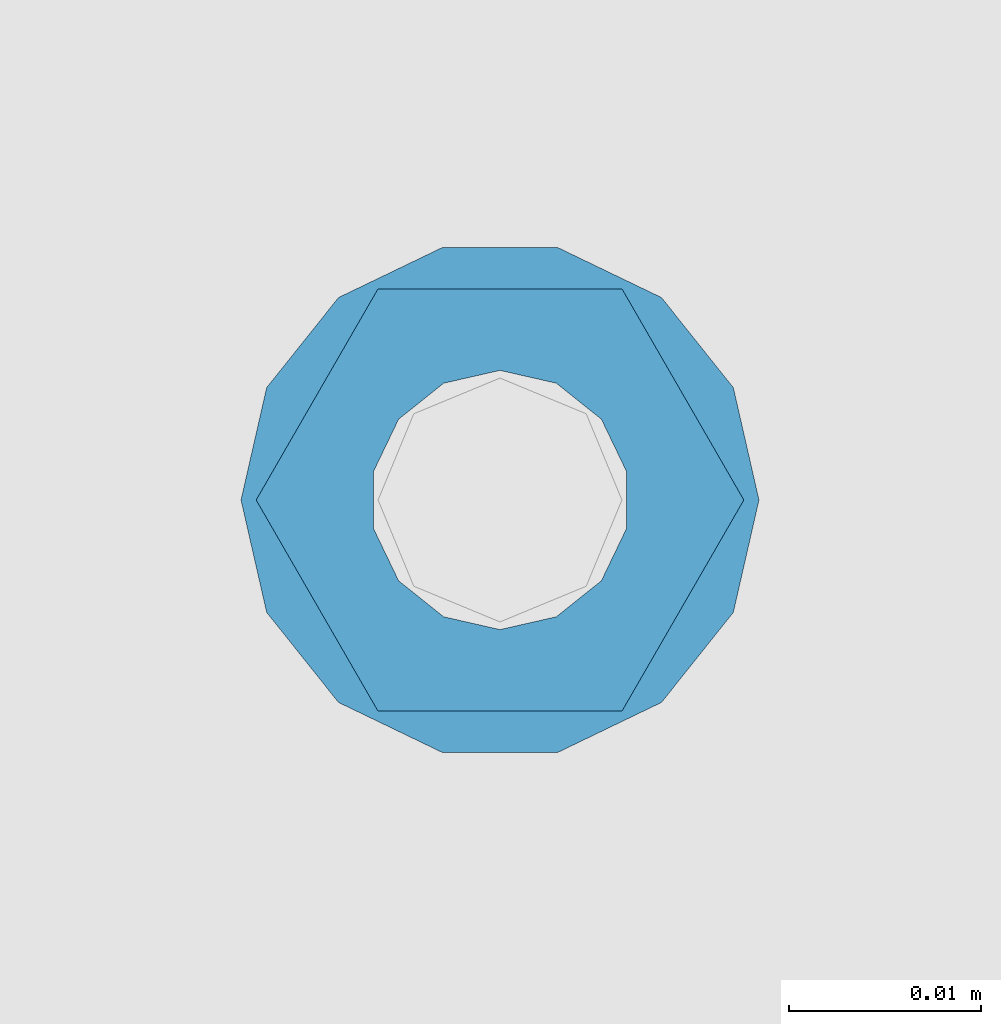
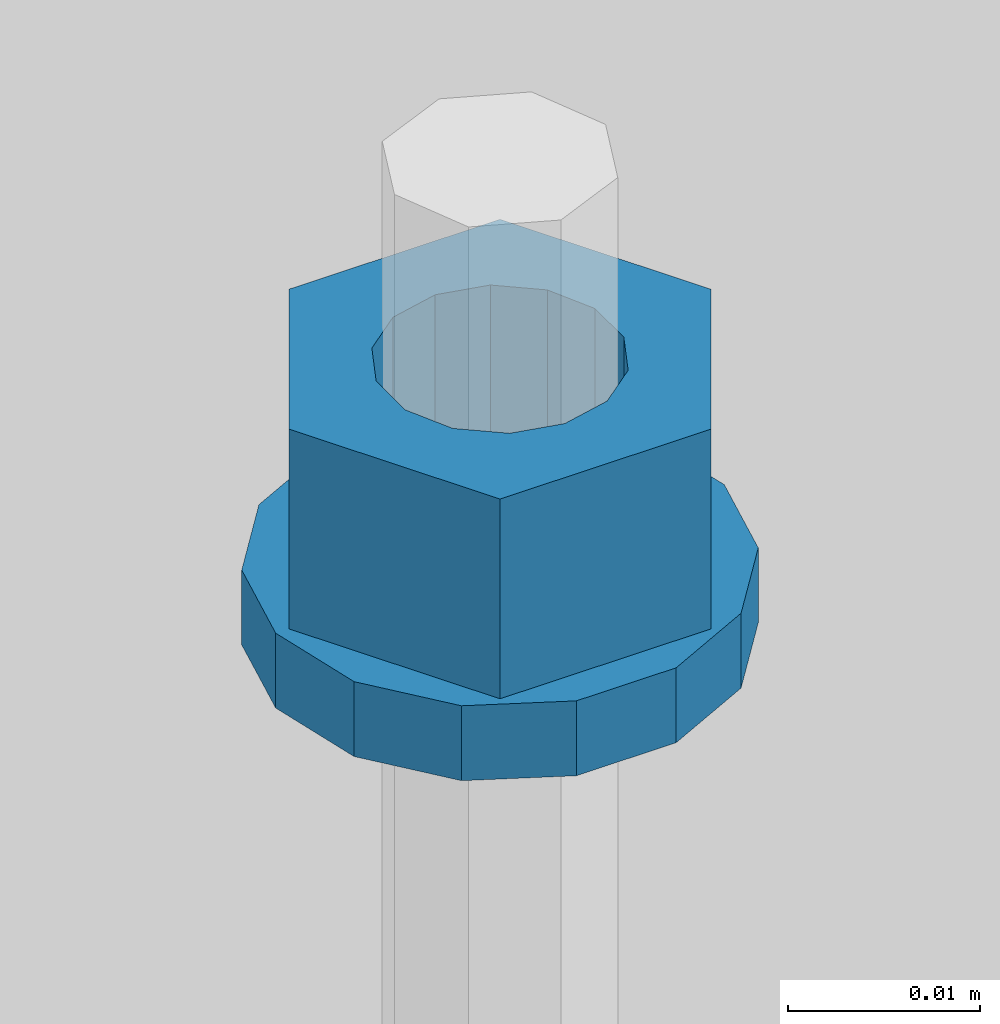
# One storey, part 651 of 1179: 2 columns, 1 element without a shape of its own.
"""IFC2X3 building model written with IfcOpenShell, lengths in millimetres."""

from ifc_helpers import new_model, si_unit, frame, origin_with_axes, place, context, subcontext, project, spatial, faceted_brep, material, type_object, element, aggregate, save


model = new_model("IFC2X3")

# Units and contexts
model_context = context("Model", 3, precision=1e-05, world=origin_with_axes())
body_context = subcontext(model_context, "Body", "Model", "MODEL_VIEW")
ifc_project = project(units=[si_unit("LENGTHUNIT", "METRE", prefix="MILLI"), si_unit("AREAUNIT", "SQUARE_METRE"), si_unit("VOLUMEUNIT", "CUBIC_METRE"), si_unit("MASSUNIT", "GRAM", prefix="KILO"), si_unit("TIMEUNIT", "SECOND"), si_unit("PLANEANGLEUNIT", "RADIAN"), si_unit("SOLIDANGLEUNIT", "STERADIAN"), si_unit("THERMODYNAMICTEMPERATUREUNIT", "DEGREE_CELSIUS"), si_unit("LUMINOUSINTENSITYUNIT", "LUMEN")], contexts=[model_context])

# Site, building, storey
site_placement = place(None, origin_with_axes())
site = spatial("IfcSite", under=ifc_project, at=site_placement, CompositionType="ELEMENT")
building_placement = place(site_placement, origin_with_axes())
building = spatial("IfcBuilding", under=site, at=building_placement, Name="Undefined", CompositionType="ELEMENT")
storey_placement = place(building_placement, origin_with_axes())
storey = spatial("IfcBuildingStorey", under=building, at=storey_placement, Name="Undefined", CompositionType="ELEMENT", Elevation=0.0)

# Assembly, columns
assembly_placement = place(storey_placement, origin_with_axes())
assembly = element("IfcElementAssembly", 1, at=assembly_placement, inside=storey, Name="BEAM", AssemblyPlace="NOTDEFINED", PredefinedType="RIGID_FRAME")
ifc_material = material(Name="STEEL/A307")
column_type_1 = type_object("IfcColumnType", Name="1/2_WASHER", PredefinedType="NOTDEFINED")
column_1_placement = place(assembly_placement, frame((1269.99998779297, 41529.0, 4235.45), z_axis=(0.0, 1.0, 0.0), x_axis=(0.0, 0.0, 1.0)))
column_1 = element("IfcColumn", 2, at=column_1_placement, type_object=column_type_1, material=ifc_material, Name="WASHER", ObjectType="1/2_WASHER", context=body_context, shape_type="Brep", body=[
    faceted_brep([(0.0, -13.4899997711182, 0.0), (0.0, -12.1540698217868, -5.85309154138758), (4.76249999999891, -12.1540698217868, -5.85309154138758), (4.76249999999891, -13.4899997711182, 0.0), (0.0, -8.41087728436833, -10.5469065195466), (4.76249999999891, -8.41087728436833, -10.5469065195466), (0.0, -3.00180734814057, -13.1517773121896), (4.76249999999891, -3.00180734814057, -13.1517773121896), (0.0, 3.00180734814057, -13.1517773121896), (4.76249999999891, 3.00180734814057, -13.1517773121896), (0.0, 8.41087728436833, -10.5469065195466), (4.76249999999891, 8.41087728436833, -10.5469065195466), (0.0, 12.1540698217868, -5.85309154138758), (4.76249999999891, 12.1540698217868, -5.85309154138758), (0.0, 13.4899997711182, 0.0), (4.76249999999891, 13.4899997711182, 0.0), (0.0, 12.1540698217868, 5.85309154138758), (4.76249999999891, 12.1540698217868, 5.85309154138758), (0.0, 8.41087728436833, 10.5469065195466), (4.76249999999891, 8.41087728436833, 10.5469065195466), (0.0, 3.00180734814057, 13.1517773121896), (4.76249999999891, 3.00180734814057, 13.1517773121896), (0.0, -3.00180734814057, 13.1517773121896), (4.76249999999891, -3.00180734814057, 13.1517773121896), (0.0, -8.41087728436833, 10.5469065195466), (4.76249999999891, -8.41087728436833, 10.5469065195466), (0.0, -12.1540698217868, 5.85309154138758), (4.76249999999891, -12.1540698217868, 5.85309154138758), (0.0, 0.0, 6.75), (0.0, 2.9287152390425, 6.08153985834178), (4.76249999999891, 2.9287152390425, 6.08153985834178), (4.76249999999891, 0.0, 6.75), (0.0, 5.27736250665839, 4.2085561625463), (4.76249999999891, 5.27736250665839, 4.2085561625463), (0.0, 6.58076340722619, 1.50201630420543), (4.76249999999891, 6.58076340722619, 1.50201630420543), (0.0, 6.58076340722619, -1.50201630420543), (4.76249999999891, 6.58076340722619, -1.50201630420543), (0.0, 5.27736250665839, -4.2085561625463), (4.76249999999891, 5.27736250665839, -4.2085561625463), (0.0, 2.9287152390425, -6.08153985834088), (4.76249999999891, 2.9287152390425, -6.08153985834088), (0.0, 0.0, -6.75), (4.76249999999891, 0.0, -6.75), (0.0, -2.9287152390425, -6.08153985834178), (4.76249999999891, -2.9287152390425, -6.08153985834178), (0.0, -5.27736250665839, -4.2085561625463), (4.76249999999891, -5.27736250665839, -4.2085561625463), (0.0, -6.58076340722619, -1.50201630420543), (4.76249999999891, -6.58076340722619, -1.50201630420543), (0.0, -6.58076340722619, 1.50201630420543), (4.76249999999891, -6.58076340722619, 1.50201630420543), (0.0, -5.27736250665839, 4.2085561625463), (4.76249999999891, -5.27736250665839, 4.2085561625463), (0.0, -2.9287152390425, 6.08153985834088), (4.76249999999891, -2.9287152390425, 6.08153985834088)], [[[0, 1, 2, 3]], [[1, 4, 5, 2]], [[4, 6, 7, 5]], [[6, 8, 9, 7]], [[8, 10, 11, 9]], [[10, 12, 13, 11]], [[12, 14, 15, 13]], [[14, 16, 17, 15]], [[16, 18, 19, 17]], [[18, 20, 21, 19]], [[20, 22, 23, 21]], [[22, 24, 25, 23]], [[24, 26, 27, 25]], [[26, 0, 3, 27]], [[28, 29, 30, 31]], [[29, 32, 33, 30]], [[32, 34, 35, 33]], [[34, 36, 37, 35]], [[36, 38, 39, 37]], [[38, 40, 41, 39]], [[40, 42, 43, 41]], [[42, 44, 45, 43]], [[44, 46, 47, 45]], [[46, 48, 49, 47]], [[48, 50, 51, 49]], [[50, 52, 53, 51]], [[52, 54, 55, 53]], [[54, 28, 31, 55]], [[5, 7, 9, 11, 13, 15, 17, 19, 21, 23, 25, 27, 3, 2], [33, 35, 37, 39, 41, 43, 45, 47, 49, 51, 53, 55, 31, 30]], [[26, 24, 22, 20, 18, 16, 14, 12, 10, 8, 6, 4, 1, 0], [54, 52, 50, 48, 46, 44, 42, 40, 38, 36, 34, 32, 29, 28]]]),
])
column_type_2 = type_object("IfcColumnType", Name="1/2_HEAVY_HEX_NUT", PredefinedType="NOTDEFINED")
column_2_placement = place(assembly_placement, frame((1269.99998779297, 41529.0, 4240.2125), z_axis=(0.0, 1.0, 0.0), x_axis=(0.0, 0.0, 1.0)))
column_2 = element("IfcColumn", 3, at=column_2_placement, type_object=column_type_2, material=ifc_material, Name="NUT", ObjectType="1/2_HEAVY_HEX_NUT", context=body_context, shape_type="Brep", body=[
    faceted_brep([(0.0, -12.7, 0.0), (0.0, -6.34999990463257, -11.0), (12.7000000000007, -6.34999990463257, -11.0), (12.7000000000007, -12.6999998092651, 0.0), (0.0, 6.34999990463257, -11.0), (12.7000000000007, 6.34999990463257, -11.0), (0.0, 12.7, 0.0), (12.7000000000007, 12.6999998092651, 0.0), (0.0, 6.34999990463257, 11.0), (12.7000000000007, 6.34999990463257, 11.0), (0.0, -6.34999990463257, 11.0), (12.7000000000007, -6.34999990463257, 11.0), (0.0, 0.0, 6.75), (0.0, 2.9287152390425, 6.08153985834178), (12.7000000000007, 2.9287152390425, 6.08153985834178), (12.7000000000007, 0.0, 6.75), (0.0, 5.27736250665839, 4.2085561625463), (12.7000000000007, 5.27736250665839, 4.2085561625463), (0.0, 6.58076340722619, 1.50201630420543), (12.7000000000007, 6.58076340722619, 1.50201630420543), (0.0, 6.58076340722619, -1.50201630420543), (12.7000000000007, 6.58076340722619, -1.50201630420543), (0.0, 5.27736250665839, -4.2085561625463), (12.7000000000007, 5.27736250665839, -4.2085561625463), (0.0, 2.9287152390425, -6.08153985834088), (12.7000000000007, 2.9287152390425, -6.08153985834088), (0.0, 0.0, -6.75), (12.7000000000007, 0.0, -6.75), (0.0, -2.9287152390425, -6.08153985834178), (12.7000000000007, -2.9287152390425, -6.08153985834178), (0.0, -5.27736250665839, -4.2085561625463), (12.7000000000007, -5.27736250665839, -4.2085561625463), (0.0, -6.58076340722619, -1.50201630420543), (12.7000000000007, -6.58076340722619, -1.50201630420543), (0.0, -6.58076340722619, 1.50201630420543), (12.7000000000007, -6.58076340722619, 1.50201630420543), (0.0, -5.27736250665839, 4.2085561625463), (12.7000000000007, -5.27736250665839, 4.2085561625463), (0.0, -2.9287152390425, 6.08153985834088), (12.7000000000007, -2.9287152390425, 6.08153985834088)], [[[0, 1, 2, 3]], [[1, 4, 5, 2]], [[4, 6, 7, 5]], [[6, 8, 9, 7]], [[8, 10, 11, 9]], [[10, 0, 3, 11]], [[12, 13, 14, 15]], [[13, 16, 17, 14]], [[16, 18, 19, 17]], [[18, 20, 21, 19]], [[20, 22, 23, 21]], [[22, 24, 25, 23]], [[24, 26, 27, 25]], [[26, 28, 29, 27]], [[28, 30, 31, 29]], [[30, 32, 33, 31]], [[32, 34, 35, 33]], [[34, 36, 37, 35]], [[36, 38, 39, 37]], [[38, 12, 15, 39]], [[5, 7, 9, 11, 3, 2], [17, 19, 21, 23, 25, 27, 29, 31, 33, 35, 37, 39, 15, 14]], [[10, 8, 6, 4, 1, 0], [38, 36, 34, 32, 30, 28, 26, 24, 22, 20, 18, 16, 13, 12]]]),
])
aggregate(assembly, [column_1, column_2])

save(model, "model.ifc")
